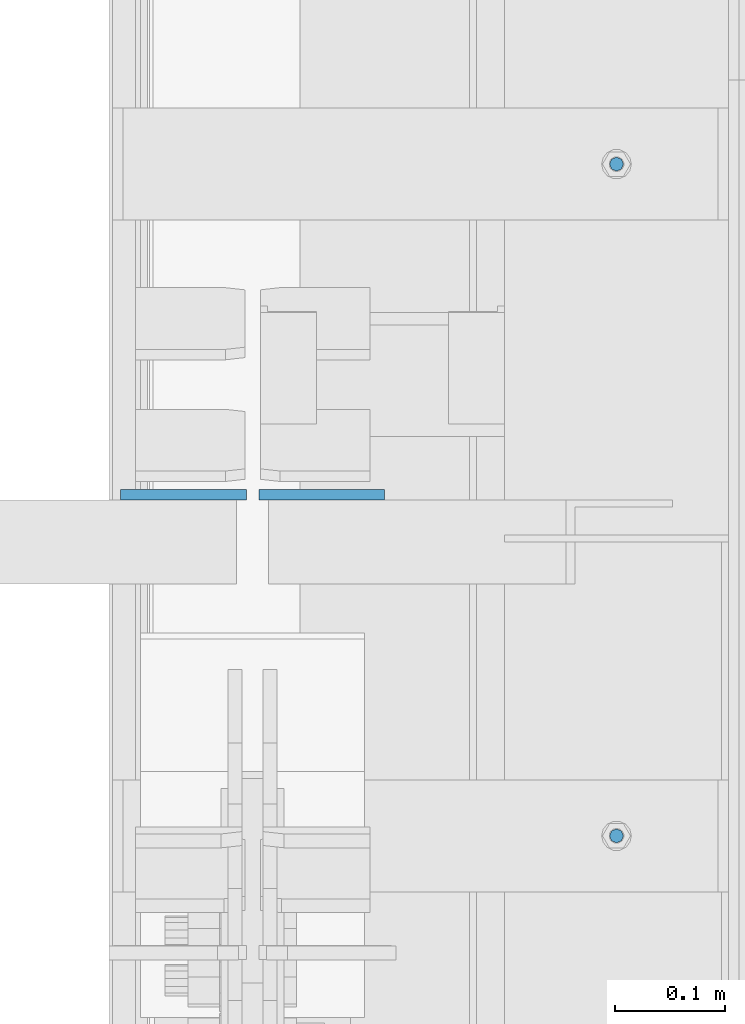
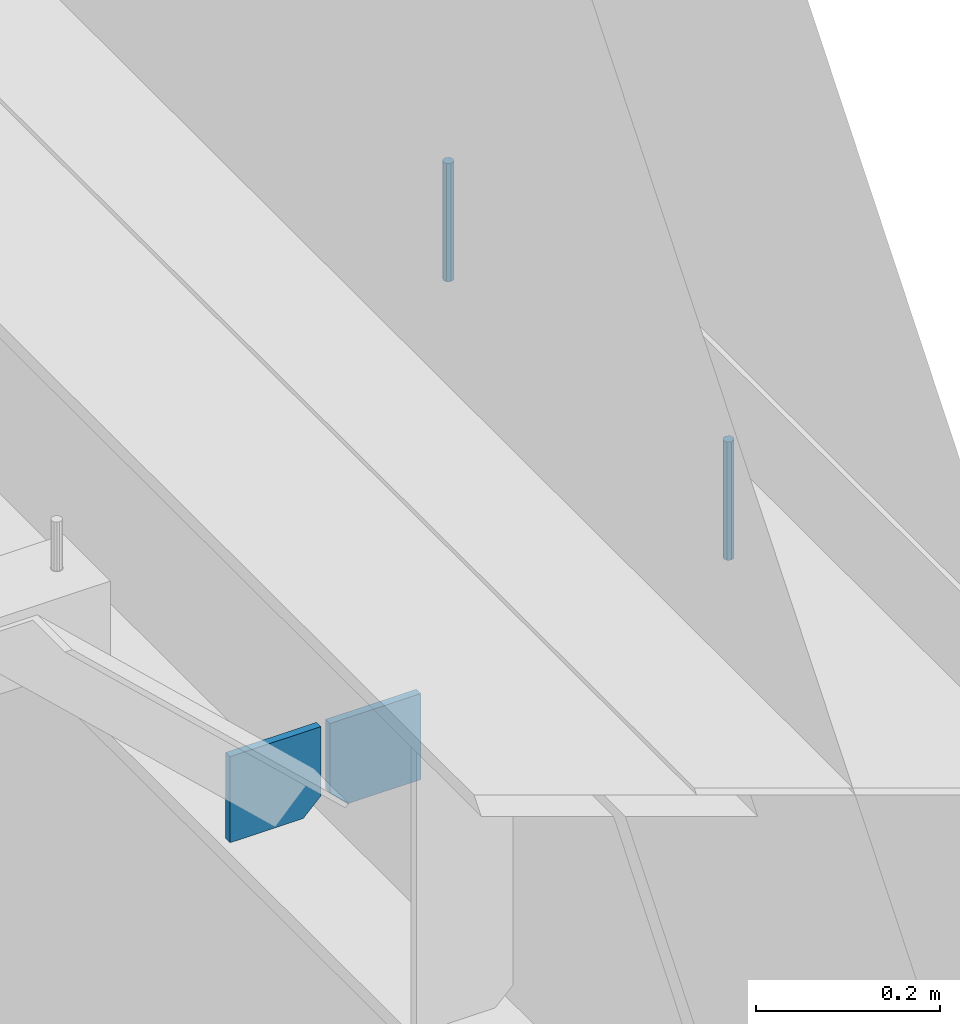
# One storey, part 437 of 1179: 4 columns, 1 element without a shape of its own.
"""IFC2X3 building model written with IfcOpenShell, lengths in millimetres."""

import ifcopenshell
import ifcopenshell.guid

model = None  # the IFC model being written
_history = None  # IfcOwnerHistory: only IFC2X3 demands one
_inside = {}  # id of a spatial element -> (the spatial element, [elements in it])
_under = {}  # id of a project, library or spatial element -> (it, [spatial elements below it])
_declared = {}  # id of a project -> (the project, [libraries it declares])
_typed = {}  # id of a type object -> (the type object, [elements of that type])
_made_of = {}  # id of a material, layer set ... -> (it, [elements and type objects made of it])


def new_model(schema):
    """Start an empty IFC model of exactly this schema.

    Asked for "IFC4X3", IfcOpenShell would pick the latest addendum, in which some entities
    have other attributes; the version numbers below select the first issue.
    IFC2X3 requires an IfcOwnerHistory on every rooted entity: one is made here for all.
    """
    global model, _history
    if schema == "IFC4X3":
        model = ifcopenshell.file(schema_version=(4, 3, 0, 0))
    else:
        model = ifcopenshell.file(schema=schema)
    _inside.clear()
    _under.clear()
    _declared.clear()
    _typed.clear()
    _made_of.clear()
    _history = None
    if model.schema == "IFC2X3":
        org = make("IfcOrganization", Name="unknown")
        user = make(
            "IfcPersonAndOrganization",
            ThePerson=make("IfcPerson", FamilyName="unknown"),
            TheOrganization=org,
        )
        app = make(
            "IfcApplication",
            ApplicationDeveloper=org,
            Version="unknown",
            ApplicationFullName="unknown",
            ApplicationIdentifier="unknown",
        )
        _history = make(
            "IfcOwnerHistory",
            OwningUser=user,
            OwningApplication=app,
            ChangeAction="ADDED",
            CreationDate=0,
        )
    return model


def make(cls, **values):
    """One entity of the class cls with the attributes given. An attribute that is None is left unset."""
    return model.create_entity(
        cls, **{name: value for name, value in values.items() if value is not None}
    )


def rooted(cls, **values):
    """An entity with a GlobalId (a new one), such as an element, a storey or a relation."""
    return make(cls, GlobalId=ifcopenshell.guid.new(), OwnerHistory=_history, **values)


def si_unit(unit_type, name, prefix=None):
    """IfcSIUnit, for example si_unit("LENGTHUNIT", "METRE", prefix="MILLI")."""
    return make("IfcSIUnit", UnitType=unit_type, Prefix=prefix, Name=name)


def assignment(units):
    """IfcUnitAssignment: the units of a project."""
    return None if units is None else make("IfcUnitAssignment", Units=units)


def point(xyz):
    """IfcCartesianPoint."""
    return None if xyz is None else make("IfcCartesianPoint", Coordinates=xyz)


def direction(xyz):
    """IfcDirection."""
    return None if xyz is None else make("IfcDirection", DirectionRatios=xyz)


def frame(location, z_axis=None, x_axis=None):
    """IfcAxis2Placement3D, a coordinate frame: its origin and axes. An axis left out is left unset."""
    return make(
        "IfcAxis2Placement3D",
        Location=point(location),
        Axis=direction(z_axis),
        RefDirection=direction(x_axis),
    )


def origin_with_axes():
    """The frame at (0, 0, 0) with the z axis (0, 0, 1) and the x axis (1, 0, 0) written out."""
    return frame((0.0, 0.0, 0.0), z_axis=(0.0, 0.0, 1.0), x_axis=(1.0, 0.0, 0.0))


def place(relative_to, where):
    """IfcLocalPlacement: puts the frame where relative to a parent placement (None: the world)."""
    return make(
        "IfcLocalPlacement", PlacementRelTo=relative_to, RelativePlacement=where
    )


def context(
    kind, dimensions, precision=None, world=None, true_north=None, identifier=None
):
    """IfcGeometricRepresentationContext, for example the 3D "Model" context."""
    return make(
        "IfcGeometricRepresentationContext",
        ContextIdentifier=identifier,
        ContextType=kind,
        CoordinateSpaceDimension=dimensions,
        Precision=precision,
        WorldCoordinateSystem=world,
        TrueNorth=true_north,
    )


def subcontext(parent, identifier, kind, view, scale=None):
    """IfcGeometricRepresentationSubContext, for example "Body" below "Model"."""
    return make(
        "IfcGeometricRepresentationSubContext",
        ContextIdentifier=identifier,
        ContextType=kind,
        ParentContext=parent,
        TargetScale=scale,
        TargetView=view,
    )


def project(units=None, contexts=None):
    """IfcProject with its units and contexts."""
    return rooted(
        "IfcProject",
        Name="project",
        RepresentationContexts=contexts,
        UnitsInContext=assignment(units),
    )


def spatial(cls, under=None, at=None, **own):
    """A site, building, storey or space (cls), placed at a placement, below another one or the project."""
    s = rooted(cls, ObjectPlacement=at, **own)
    if under is not None:
        _under.setdefault(under.id(), (under, []))[1].append(s)
    return s


def faces_of(points, faces, orient=None, outer=None):
    """IfcFace entities. A face is a list of loops; a loop is a list of indices into points, from 0.

    orient and outer hold one flag for each loop. By default every Orientation is true, the
    first loop of a face is its IfcFaceOuterBound and the others are IfcFaceBound.
    """
    made = []
    for i, loops in enumerate(faces):
        bounds = []
        for j, loop in enumerate(loops):
            is_outer = j == 0 if outer is None else outer[i][j]
            bounds.append(
                make(
                    "IfcFaceOuterBound" if is_outer else "IfcFaceBound",
                    Bound=make("IfcPolyLoop", Polygon=[points[k] for k in loop]),
                    Orientation=True if orient is None else orient[i][j],
                )
            )
        made.append(make("IfcFace", Bounds=bounds))
    return made


def faceted_brep(points, faces, orient=None, outer=None, voids=None):
    """IfcFacetedBrep: a solid bounded by flat faces; with voids (closed shells), ...WithVoids."""
    shared = [point(p) for p in points]
    hull = make("IfcClosedShell", CfsFaces=faces_of(shared, faces, orient, outer))
    if voids is None:
        return make("IfcFacetedBrep", Outer=hull)
    return make(
        "IfcFacetedBrepWithVoids",
        Outer=hull,
        Voids=[
            make(cls, CfsFaces=faces_of(shared, fs, o, b)) for cls, fs, o, b in voids
        ],
    )


def shape(context_of_items, identifier, shape_type, items):
    """IfcShapeRepresentation: the items that make up one representation, for example the "Body"."""
    return make(
        "IfcShapeRepresentation",
        ContextOfItems=context_of_items,
        RepresentationIdentifier=identifier,
        RepresentationType=shape_type,
        Items=items,
    )


def material(Name=None, Category=None):
    """IfcMaterial."""
    return make("IfcMaterial", Name=Name, Category=Category)


def made_of(thing, what):
    """Note that an element or type object is made of a material, layer set ...; save() writes the relation."""
    if what is not None:
        _made_of.setdefault(what.id(), (what, []))[1].append(thing)
    return thing


def type_object(cls, material=None, **own):
    """A type object (cls), such as IfcWallType, which elements share."""
    return made_of(rooted(cls, **own), material)


def element(
    cls,
    number,
    at=None,
    inside=None,
    cuts=None,
    type_object=None,
    material=None,
    context=None,
    identifier="Body",
    shape_type=None,
    held_by="IfcProductDefinitionShape",
    body=None,
    shapes=None,
    **own,
):
    """One element of the class cls, such as IfcWall. Its Tag is "e" and its number.

    at: its placement. inside: the storey or other place that contains it. cuts: it is an
    opening in that element (IfcRelVoidsElement). A single representation is given by context,
    identifier, shape_type and body (its items); several are given by shapes. held_by: the class
    of the entity that holds the representations. save() writes the other relations.
    """
    e = rooted(cls, Tag="e%d" % number, ObjectPlacement=at, **own)
    if body is not None:
        shapes = [shape(context, identifier, shape_type, body)]
    if shapes is not None:
        e.Representation = make(held_by, Representations=shapes)
    if inside is not None:
        _inside.setdefault(inside.id(), (inside, []))[1].append(e)
    if cuts is not None:
        rooted(
            "IfcRelVoidsElement", RelatingBuildingElement=cuts, RelatedOpeningElement=e
        )
    if type_object is not None:
        _typed.setdefault(type_object.id(), (type_object, []))[1].append(e)
    return made_of(e, material)


def aggregate(whole, parts):
    """IfcRelAggregates: a whole, such as a stair, and the parts it consists of."""
    return rooted("IfcRelAggregates", RelatingObject=whole, RelatedObjects=parts)


def save(model, path):
    """Write the relations noted so far, then the file.

    IfcRelAggregates (storeys below a building ...), IfcRelContainedInSpatialStructure (elements
    in a storey), IfcRelDefinesByType, IfcRelAssociatesMaterial and IfcRelDeclares: one each for
    every whole, place, type object, material and project.
    """
    for whole, parts in _under.values():
        aggregate(whole, parts)
    for where, things in _inside.values():
        rooted(
            "IfcRelContainedInSpatialStructure",
            RelatedElements=things,
            RelatingStructure=where,
        )
    for kind, things in _typed.values():
        rooted("IfcRelDefinesByType", RelatedObjects=things, RelatingType=kind)
    for what, things in _made_of.values():
        rooted("IfcRelAssociatesMaterial", RelatedObjects=things, RelatingMaterial=what)
    for by, libraries in _declared.values():
        rooted("IfcRelDeclares", RelatingContext=by, RelatedDefinitions=libraries)
    model.write(path)


model = new_model("IFC2X3")

# Units and contexts
model_context = context("Model", 3, precision=1e-05, world=origin_with_axes())
body_context = subcontext(model_context, "Body", "Model", "MODEL_VIEW")
ifc_project = project(units=[si_unit("LENGTHUNIT", "METRE", prefix="MILLI"), si_unit("AREAUNIT", "SQUARE_METRE"), si_unit("VOLUMEUNIT", "CUBIC_METRE"), si_unit("MASSUNIT", "GRAM", prefix="KILO"), si_unit("TIMEUNIT", "SECOND"), si_unit("PLANEANGLEUNIT", "RADIAN"), si_unit("SOLIDANGLEUNIT", "STERADIAN"), si_unit("THERMODYNAMICTEMPERATUREUNIT", "DEGREE_CELSIUS"), si_unit("LUMINOUSINTENSITYUNIT", "LUMEN")], contexts=[model_context])

# Site, building, storey
site_placement = place(None, origin_with_axes())
site = spatial("IfcSite", under=ifc_project, at=site_placement, CompositionType="ELEMENT")
building_placement = place(site_placement, origin_with_axes())
building = spatial("IfcBuilding", under=site, at=building_placement, Name="Undefined", CompositionType="ELEMENT")
storey_placement = place(building_placement, origin_with_axes())
storey = spatial("IfcBuildingStorey", under=building, at=storey_placement, Name="Undefined", CompositionType="ELEMENT", Elevation=0.0)

# Assembly, columns
assembly_placement = place(storey_placement, origin_with_axes())
assembly = element("IfcElementAssembly", 1, at=assembly_placement, inside=storey, Name="BEAM", AssemblyPlace="NOTDEFINED", PredefinedType="RIGID_FRAME")
ifc_material_1 = material(Name="STEEL/A36")
column_type_1 = type_object("IfcColumnType", PredefinedType="NOTDEFINED")
column_1_placement = place(assembly_placement, frame((24245.09375, 16273.4625, 3702.05), z_axis=(1.0, 0.0, 0.0), x_axis=(0.0, 0.0, 1.0)))
column_1 = element("IfcColumn", 2, at=column_1_placement, type_object=column_type_1, material=ifc_material_1, Name="PLATE", context=body_context, shape_type="Brep", body=[
    faceted_brep([(22.2250000000004, 4.76250000000073, 57.1500000000015), (0.0, 4.76250000000073, 34.9249999999993), (0.0, -4.76250000000073, 34.9249999999993), (22.2250000000004, -4.76250000000073, 57.1500000000015), (114.300000000001, 4.76250000000073, 57.1500000000015), (114.300000000001, 4.76250000000073, -57.1500000000015), (0.0, 4.76250000000073, -57.1500000000015), (114.300000000001, -4.76250000000073, 57.1500000000015), (0.0, -4.76250000000073, -57.1500000000015), (114.300000000001, -4.76250000000073, -57.1500000000015)], [[[0, 1, 2, 3]], [[4, 5, 6, 1, 0]], [[7, 4, 0, 3]], [[8, 9, 7, 3, 2]], [[8, 6, 5, 9]], [[7, 9, 5, 4]], [[6, 8, 2, 1]]]),
])
column_2_placement = place(assembly_placement, frame((24370.50625, 16273.4625, 3702.05), z_axis=(-1.0, 0.0, 0.0), x_axis=(0.0, 0.0, 1.0)))
column_2 = element("IfcColumn", 3, at=column_2_placement, type_object=column_type_1, material=ifc_material_1, Name="PLATE", context=body_context, shape_type="Brep", body=[
    faceted_brep([(22.2250000000004, 4.76250000000073, 57.1500000000015), (0.0, 4.76250000000073, 34.9249999999993), (0.0, -4.76250000000073, 34.9249999999993), (22.2250000000004, -4.76250000000073, 57.1500000000015), (114.300000000001, 4.76250000000073, 57.1500000000015), (114.300000000001, 4.76250000000073, -57.1500000000015), (0.0, 4.76250000000073, -57.1500000000015), (114.300000000001, -4.76250000000073, 57.1500000000015), (0.0, -4.76250000000073, -57.1500000000015), (114.300000000001, -4.76250000000073, -57.1500000000015)], [[[0, 1, 2, 3]], [[4, 5, 6, 1, 0]], [[7, 4, 0, 3]], [[8, 9, 7, 3, 2]], [[8, 6, 5, 9]], [[7, 9, 5, 4]], [[6, 8, 2, 1]]]),
])
ifc_material_2 = material(Name="STEEL/A307")
column_type_2 = type_object("IfcColumnType", PredefinedType="NOTDEFINED")
column_3_placement = place(assembly_placement, frame((24638.0, 16573.5, 4108.45), z_axis=(0.0, 1.0, 0.0), x_axis=(0.0, 0.0, 1.0)))
column_3 = element("IfcColumn", 4, at=column_3_placement, type_object=column_type_2, material=ifc_material_2, Name="THREADED ROD", context=body_context, shape_type="Brep", body=[
    faceted_brep([(0.0, -6.34999999999854, 0.0), (0.0, -4.49012806053361, -4.49012806053452), (157.162499999999, -4.49012806053361, -4.49012806053361), (157.162499999999, -6.34999999999854, 0.0), (0.0, 0.0, -6.34999999999991), (157.162499999999, 0.0, -6.34999999999854), (0.0, 4.49012806053361, -4.49012806053452), (157.162499999999, 4.49012806053361, -4.49012806053361), (0.0, 6.34999999999854, 0.0), (157.162499999999, 6.34999999999854, 0.0), (0.0, 4.49012806053361, 4.49012806053452), (157.162499999999, 4.49012806053361, 4.49012806053361), (0.0, 0.0, 6.34999999999991), (157.162499999999, 0.0, 6.34999999999854), (0.0, -4.49012806053361, 4.49012806053452), (157.162499999999, -4.49012806053361, 4.49012806053361)], [[[0, 1, 2, 3]], [[1, 4, 5, 2]], [[4, 6, 7, 5]], [[6, 8, 9, 7]], [[8, 10, 11, 9]], [[10, 12, 13, 11]], [[12, 14, 15, 13]], [[14, 0, 3, 15]], [[5, 7, 9, 11, 13, 15, 3, 2]], [[14, 12, 10, 8, 6, 4, 1, 0]]]),
])
column_4_placement = place(assembly_placement, frame((24638.0, 15963.9, 4108.45), z_axis=(0.0, 1.0, 0.0), x_axis=(0.0, 0.0, 1.0)))
column_4 = element("IfcColumn", 5, at=column_4_placement, type_object=column_type_2, material=ifc_material_2, Name="THREADED ROD", context=body_context, shape_type="Brep", body=[
    faceted_brep([(0.0, -6.34999999999854, 0.0), (0.0, -4.49012806053361, -4.49012806053452), (157.162499999999, -4.49012806053361, -4.49012806053361), (157.162499999999, -6.34999999999854, 0.0), (0.0, 0.0, -6.34999999999991), (157.162499999999, 0.0, -6.34999999999854), (0.0, 4.49012806053361, -4.49012806053452), (157.162499999999, 4.49012806053361, -4.49012806053361), (0.0, 6.34999999999854, 0.0), (157.162499999999, 6.34999999999854, 0.0), (0.0, 4.49012806053361, 4.49012806053452), (157.162499999999, 4.49012806053361, 4.49012806053361), (0.0, 0.0, 6.34999999999991), (157.162499999999, 0.0, 6.34999999999854), (0.0, -4.49012806053361, 4.49012806053452), (157.162499999999, -4.49012806053361, 4.49012806053361)], [[[0, 1, 2, 3]], [[1, 4, 5, 2]], [[4, 6, 7, 5]], [[6, 8, 9, 7]], [[8, 10, 11, 9]], [[10, 12, 13, 11]], [[12, 14, 15, 13]], [[14, 0, 3, 15]], [[5, 7, 9, 11, 13, 15, 3, 2]], [[14, 12, 10, 8, 6, 4, 1, 0]]]),
])
aggregate(assembly, [column_3, column_4, column_1, column_2])

save(model, "model.ifc")
